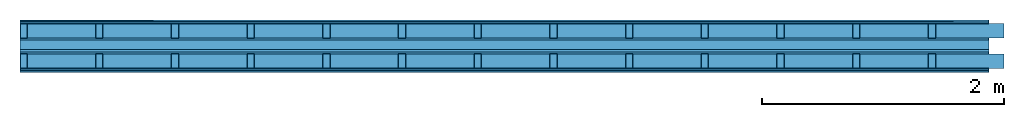
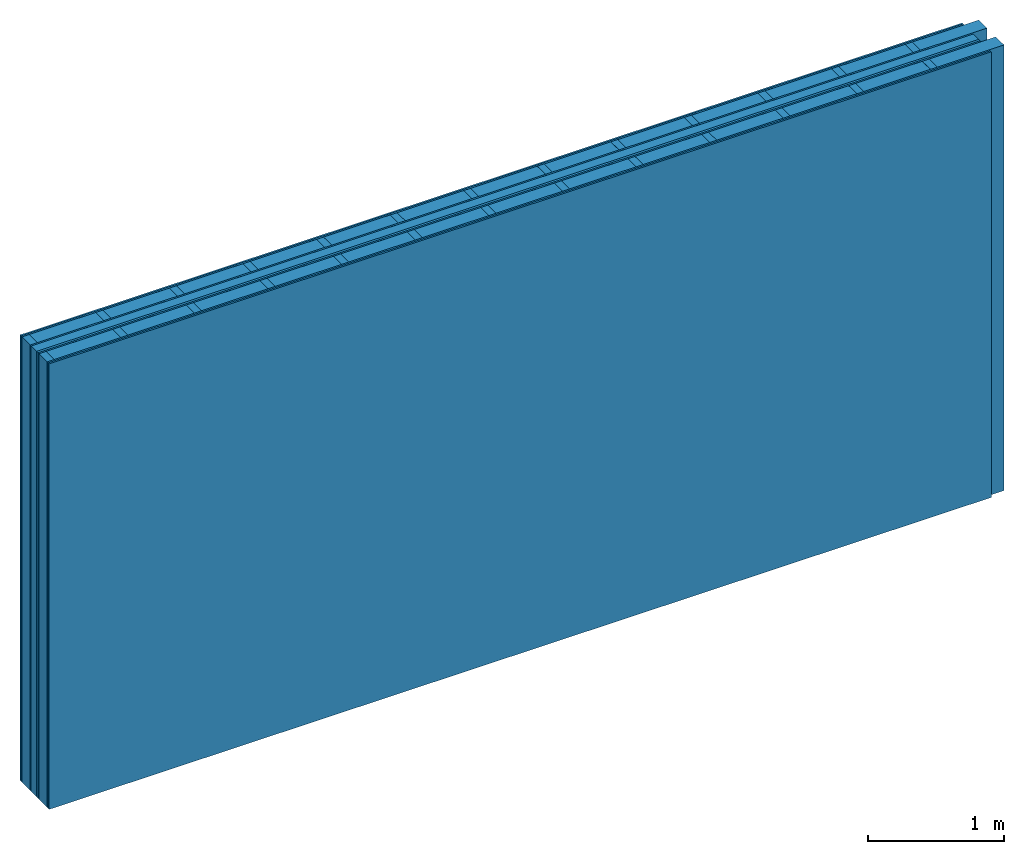
# One storey: 8 plates, 4 members, 1 element without a shape of its own.
"""IFC4 building model written with IfcOpenShell, lengths in metres."""

import ifcopenshell
import ifcopenshell.guid

model = None  # the IFC model being written
_history = None  # IfcOwnerHistory: only IFC2X3 demands one
_inside = {}  # id of a spatial element -> (the spatial element, [elements in it])
_under = {}  # id of a project, library or spatial element -> (it, [spatial elements below it])
_declared = {}  # id of a project -> (the project, [libraries it declares])
_typed = {}  # id of a type object -> (the type object, [elements of that type])
_made_of = {}  # id of a material, layer set ... -> (it, [elements and type objects made of it])


def new_model(schema):
    """Start an empty IFC model of exactly this schema.

    Asked for "IFC4X3", IfcOpenShell would pick the latest addendum, in which some entities
    have other attributes; the version numbers below select the first issue.
    IFC2X3 requires an IfcOwnerHistory on every rooted entity: one is made here for all.
    """
    global model, _history
    if schema == "IFC4X3":
        model = ifcopenshell.file(schema_version=(4, 3, 0, 0))
    else:
        model = ifcopenshell.file(schema=schema)
    _inside.clear()
    _under.clear()
    _declared.clear()
    _typed.clear()
    _made_of.clear()
    _history = None
    if model.schema == "IFC2X3":
        org = make("IfcOrganization", Name="unknown")
        user = make(
            "IfcPersonAndOrganization",
            ThePerson=make("IfcPerson", FamilyName="unknown"),
            TheOrganization=org,
        )
        app = make(
            "IfcApplication",
            ApplicationDeveloper=org,
            Version="unknown",
            ApplicationFullName="unknown",
            ApplicationIdentifier="unknown",
        )
        _history = make(
            "IfcOwnerHistory",
            OwningUser=user,
            OwningApplication=app,
            ChangeAction="ADDED",
            CreationDate=0,
        )
    return model


def make(cls, **values):
    """One entity of the class cls with the attributes given. An attribute that is None is left unset."""
    return model.create_entity(
        cls, **{name: value for name, value in values.items() if value is not None}
    )


def rooted(cls, **values):
    """An entity with a GlobalId (a new one), such as an element, a storey or a relation."""
    return make(cls, GlobalId=ifcopenshell.guid.new(), OwnerHistory=_history, **values)


def si_unit(unit_type, name, prefix=None):
    """IfcSIUnit, for example si_unit("LENGTHUNIT", "METRE", prefix="MILLI")."""
    return make("IfcSIUnit", UnitType=unit_type, Prefix=prefix, Name=name)


def derived_unit(unit_type, elements):
    """IfcDerivedUnit: a product of units, each with its exponent."""
    return make(
        "IfcDerivedUnit",
        Elements=[
            make("IfcDerivedUnitElement", Unit=unit, Exponent=power)
            for unit, power in elements
        ],
        UnitType=unit_type,
    )


def assignment(units):
    """IfcUnitAssignment: the units of a project."""
    return None if units is None else make("IfcUnitAssignment", Units=units)


def point(xyz):
    """IfcCartesianPoint."""
    return None if xyz is None else make("IfcCartesianPoint", Coordinates=xyz)


def direction(xyz):
    """IfcDirection."""
    return None if xyz is None else make("IfcDirection", DirectionRatios=xyz)


def frame(location, z_axis=None, x_axis=None):
    """IfcAxis2Placement3D, a coordinate frame: its origin and axes. An axis left out is left unset."""
    return make(
        "IfcAxis2Placement3D",
        Location=point(location),
        Axis=direction(z_axis),
        RefDirection=direction(x_axis),
    )


def frame_2d(location, x_axis=None):
    """IfcAxis2Placement2D, a coordinate frame in the plane: its origin and x axis."""
    return make(
        "IfcAxis2Placement2D", Location=point(location), RefDirection=direction(x_axis)
    )


def origin():
    """The frame at (0, 0, 0) with its axes left unset."""
    return frame((0.0, 0.0, 0.0))


def origin_with_axes():
    """The frame at (0, 0, 0) with the z axis (0, 0, 1) and the x axis (1, 0, 0) written out."""
    return frame((0.0, 0.0, 0.0), z_axis=(0.0, 0.0, 1.0), x_axis=(1.0, 0.0, 0.0))


def place(relative_to, where):
    """IfcLocalPlacement: puts the frame where relative to a parent placement (None: the world)."""
    return make(
        "IfcLocalPlacement", PlacementRelTo=relative_to, RelativePlacement=where
    )


def context(
    kind, dimensions, precision=None, world=None, true_north=None, identifier=None
):
    """IfcGeometricRepresentationContext, for example the 3D "Model" context."""
    return make(
        "IfcGeometricRepresentationContext",
        ContextIdentifier=identifier,
        ContextType=kind,
        CoordinateSpaceDimension=dimensions,
        Precision=precision,
        WorldCoordinateSystem=world,
        TrueNorth=true_north,
    )


def project(units=None, contexts=None):
    """IfcProject with its units and contexts."""
    return rooted(
        "IfcProject",
        Name="project",
        RepresentationContexts=contexts,
        UnitsInContext=assignment(units),
    )


def spatial(cls, under=None, at=None, **own):
    """A site, building, storey or space (cls), placed at a placement, below another one or the project."""
    s = rooted(cls, ObjectPlacement=at, **own)
    if under is not None:
        _under.setdefault(under.id(), (under, []))[1].append(s)
    return s


def profile(cls, at=None, kind="AREA", **sizes):
    """A parametric profile (cls). Its sizes go by their IFC names, for example OverallWidth=200.0."""
    return make(cls, ProfileType=kind, Position=at, **sizes)


def rectangle(**sizes):
    """IfcRectangleProfileDef."""
    return profile("IfcRectangleProfileDef", **sizes)


def extrude(swept, where, along, depth):
    """IfcExtrudedAreaSolid: the profile swept, set in the frame where, extruded along a direction by depth."""
    return make(
        "IfcExtrudedAreaSolid",
        SweptArea=swept,
        Position=where,
        ExtrudedDirection=direction(along),
        Depth=depth,
    )


def shape(context_of_items, identifier, shape_type, items):
    """IfcShapeRepresentation: the items that make up one representation, for example the "Body"."""
    return make(
        "IfcShapeRepresentation",
        ContextOfItems=context_of_items,
        RepresentationIdentifier=identifier,
        RepresentationType=shape_type,
        Items=items,
    )


def material(Name=None, Category=None):
    """IfcMaterial."""
    return make("IfcMaterial", Name=Name, Category=Category)


def layer(
    of_material, thickness, ventilated=None, Name=None, Category=None, Priority=None
):
    """IfcMaterialLayer: one layer of a wall or slab, of a material (None: an air gap)."""
    return make(
        "IfcMaterialLayer",
        Material=of_material,
        LayerThickness=thickness,
        IsVentilated=ventilated,
        Name=Name,
        Category=Category,
        Priority=Priority,
    )


def layer_set(layers, Name=None):
    """IfcMaterialLayerSet."""
    return make("IfcMaterialLayerSet", MaterialLayers=layers, LayerSetName=Name)


def made_of(thing, what):
    """Note that an element or type object is made of a material, layer set ...; save() writes the relation."""
    if what is not None:
        _made_of.setdefault(what.id(), (what, []))[1].append(thing)
    return thing


def type_object(cls, material=None, **own):
    """A type object (cls), such as IfcWallType, which elements share."""
    return made_of(rooted(cls, **own), material)


def element(
    cls,
    number,
    at=None,
    inside=None,
    cuts=None,
    type_object=None,
    material=None,
    context=None,
    identifier="Body",
    shape_type=None,
    held_by="IfcProductDefinitionShape",
    body=None,
    shapes=None,
    **own,
):
    """One element of the class cls, such as IfcWall. Its Tag is "e" and its number.

    at: its placement. inside: the storey or other place that contains it. cuts: it is an
    opening in that element (IfcRelVoidsElement). A single representation is given by context,
    identifier, shape_type and body (its items); several are given by shapes. held_by: the class
    of the entity that holds the representations. save() writes the other relations.
    """
    e = rooted(cls, Tag="e%d" % number, ObjectPlacement=at, **own)
    if body is not None:
        shapes = [shape(context, identifier, shape_type, body)]
    if shapes is not None:
        e.Representation = make(held_by, Representations=shapes)
    if inside is not None:
        _inside.setdefault(inside.id(), (inside, []))[1].append(e)
    if cuts is not None:
        rooted(
            "IfcRelVoidsElement", RelatingBuildingElement=cuts, RelatedOpeningElement=e
        )
    if type_object is not None:
        _typed.setdefault(type_object.id(), (type_object, []))[1].append(e)
    return made_of(e, material)


def aggregate(whole, parts):
    """IfcRelAggregates: a whole, such as a stair, and the parts it consists of."""
    return rooted("IfcRelAggregates", RelatingObject=whole, RelatedObjects=parts)


def save(model, path):
    """Write the relations noted so far, then the file.

    IfcRelAggregates (storeys below a building ...), IfcRelContainedInSpatialStructure (elements
    in a storey), IfcRelDefinesByType, IfcRelAssociatesMaterial and IfcRelDeclares: one each for
    every whole, place, type object, material and project.
    """
    for whole, parts in _under.values():
        aggregate(whole, parts)
    for where, things in _inside.values():
        rooted(
            "IfcRelContainedInSpatialStructure",
            RelatedElements=things,
            RelatingStructure=where,
        )
    for kind, things in _typed.values():
        rooted("IfcRelDefinesByType", RelatedObjects=things, RelatingType=kind)
    for what, things in _made_of.values():
        rooted("IfcRelAssociatesMaterial", RelatedObjects=things, RelatingMaterial=what)
    for by, libraries in _declared.values():
        rooted("IfcRelDeclares", RelatingContext=by, RelatedDefinitions=libraries)
    model.write(path)


model = new_model("IFC4")

# Units and contexts
plan_context = context("Plan", 3, precision=1e-05, world=origin(), true_north=direction((0.0, 1.0)))
model_context = context("Model", 3, precision=1e-05, world=origin(), true_north=direction((0.0, 1.0)))
ifc_project = project(units=[si_unit("LENGTHUNIT", "METRE"), derived_unit("SOUNDPRESSUREUNIT", [(si_unit("PRESSUREUNIT", "PASCAL", prefix="MICRO"), 0)]), si_unit("ENERGYUNIT", "JOULE", prefix="MEGA"), si_unit("MASSUNIT", "GRAM", prefix="KILO"), derived_unit("THERMALTRANSMITTANCEUNIT", [(si_unit("POWERUNIT", "WATT"), 1), (si_unit("AREAUNIT", "SQUARE_METRE"), -1), (si_unit("THERMODYNAMICTEMPERATUREUNIT", "KELVIN"), -1)]), derived_unit("AREADENSITYUNIT", [(si_unit("MASSUNIT", "GRAM", prefix="KILO"), 1), (si_unit("AREAUNIT", "SQUARE_METRE"), -1)]), derived_unit("USERDEFINED", [(si_unit("ENERGYUNIT", "JOULE", prefix="MEGA"), 1), (si_unit("AREAUNIT", "SQUARE_METRE"), -1)])], contexts=[plan_context, model_context])

# Site, building, storey
site = spatial("IfcSite", under=ifc_project)
building_placement = place(None, origin())
building = spatial("IfcBuilding", under=site, at=building_placement)
storey_placement = place(building_placement, origin())
storey = spatial("IfcBuildingStorey", under=building, at=storey_placement)

# Wall, members, plates
ifc_material_1 = material(Name="Glued joints")
ifc_layer_1 = layer(ifc_material_1, 0.0, Name="Surface")
ifc_material_2 = material(Category="03.007")
ifc_layer_2 = layer(ifc_material_2, 0.015, Name="room side 2nd layer")
ifc_layer_3 = layer(ifc_material_2, 0.015, Name="room side 1st layer")
ifc_material_3 = material(Name="of the art")
ifc_layer_4 = layer(ifc_material_3, 0.0, Name="Bond")
ifc_layer_5 = layer(None, 0.12, Name="Support")
ifc_layer_6 = layer(ifc_material_3, 0.0, Name="Bond")
ifc_layer_7 = layer(ifc_material_2, 0.015, Name="outside 1st layer")
ifc_material_4 = material()
ifc_layer_8 = layer(ifc_material_4, 0.08, Name="Intermediate insulation")
ifc_material_5 = material(Name="Air")
ifc_layer_9 = layer(ifc_material_5, 0.02, Name="Air gap")
ifc_layer_10 = layer(ifc_material_2, 0.015, Name="outside 1st layer")
ifc_layer_11 = layer(ifc_material_3, 0.0, Name="Bond")
ifc_layer_12 = layer(None, 0.12, Name="Support")
ifc_layer_13 = layer(ifc_material_3, 0.0, Name="Bond")
ifc_layer_14 = layer(ifc_material_2, 0.015, Name="room side 1st layer")
ifc_layer_15 = layer(ifc_material_2, 0.015, Name="room side 2nd layer")
ifc_layer_16 = layer(ifc_material_1, 0.0, Name="Surface")
ifc_layer_set = layer_set([ifc_layer_1, ifc_layer_2, ifc_layer_3, ifc_layer_4, ifc_layer_5, ifc_layer_6, ifc_layer_7, ifc_layer_8, ifc_layer_9, ifc_layer_10, ifc_layer_11, ifc_layer_12, ifc_layer_13, ifc_layer_14, ifc_layer_15, ifc_layer_16])
wall_type = type_object("IfcWallType", Name="B0034", PredefinedType="NOTDEFINED", material=ifc_layer_set)
wall_placement = place(None, frame((0.0, 0.0, 0.0), z_axis=(0.0, -1.0, 0.0), x_axis=(1.0, 0.0, 0.0)))
wall = element("IfcWall", 1, at=wall_placement, inside=storey, type_object=wall_type, material=ifc_layer_set, Name="Wall #1")
ifc_material_6 = material()
member_1_placement = place(wall_placement, origin())
member_1 = element("IfcMember", 2, at=member_1_placement, material=ifc_material_6, Name="Support", context=plan_context, shape_type="SweptSolid", body=[
    extrude(rectangle(XDim=0.06, YDim=0.12, at=frame_2d((0.03, 0.06), x_axis=(1.0, 0.0))), frame((0.0, 4.0, 0.03), z_axis=(0.0, -1.0, 0.0), x_axis=(1.0, 0.0, 0.0)), (0.0, 0.0, 1.0), 4.0),
    extrude(rectangle(XDim=0.06, YDim=0.12, at=frame_2d((0.03, 0.06), x_axis=(1.0, 0.0))), frame((0.625, 4.0, 0.03), z_axis=(0.0, -1.0, 0.0), x_axis=(1.0, 0.0, 0.0)), (0.0, 0.0, 1.0), 4.0),
    extrude(rectangle(XDim=0.06, YDim=0.12, at=frame_2d((0.03, 0.06), x_axis=(1.0, 0.0))), frame((1.25, 4.0, 0.03), z_axis=(0.0, -1.0, 0.0), x_axis=(1.0, 0.0, 0.0)), (0.0, 0.0, 1.0), 4.0),
    extrude(rectangle(XDim=0.06, YDim=0.12, at=frame_2d((0.03, 0.06), x_axis=(1.0, 0.0))), frame((1.875, 4.0, 0.03), z_axis=(0.0, -1.0, 0.0), x_axis=(1.0, 0.0, 0.0)), (0.0, 0.0, 1.0), 4.0),
    extrude(rectangle(XDim=0.06, YDim=0.12, at=frame_2d((0.03, 0.06), x_axis=(1.0, 0.0))), frame((2.5, 4.0, 0.03), z_axis=(0.0, -1.0, 0.0), x_axis=(1.0, 0.0, 0.0)), (0.0, 0.0, 1.0), 4.0),
    extrude(rectangle(XDim=0.06, YDim=0.12, at=frame_2d((0.03, 0.06), x_axis=(1.0, 0.0))), frame((3.125, 4.0, 0.03), z_axis=(0.0, -1.0, 0.0), x_axis=(1.0, 0.0, 0.0)), (0.0, 0.0, 1.0), 4.0),
    extrude(rectangle(XDim=0.06, YDim=0.12, at=frame_2d((0.03, 0.06), x_axis=(1.0, 0.0))), frame((3.75, 4.0, 0.03), z_axis=(0.0, -1.0, 0.0), x_axis=(1.0, 0.0, 0.0)), (0.0, 0.0, 1.0), 4.0),
    extrude(rectangle(XDim=0.06, YDim=0.12, at=frame_2d((0.03, 0.06), x_axis=(1.0, 0.0))), frame((4.375, 4.0, 0.03), z_axis=(0.0, -1.0, 0.0), x_axis=(1.0, 0.0, 0.0)), (0.0, 0.0, 1.0), 4.0),
    extrude(rectangle(XDim=0.06, YDim=0.12, at=frame_2d((0.03, 0.06), x_axis=(1.0, 0.0))), frame((5.0, 4.0, 0.03), z_axis=(0.0, -1.0, 0.0), x_axis=(1.0, 0.0, 0.0)), (0.0, 0.0, 1.0), 4.0),
    extrude(rectangle(XDim=0.06, YDim=0.12, at=frame_2d((0.03, 0.06), x_axis=(1.0, 0.0))), frame((5.625, 4.0, 0.03), z_axis=(0.0, -1.0, 0.0), x_axis=(1.0, 0.0, 0.0)), (0.0, 0.0, 1.0), 4.0),
    extrude(rectangle(XDim=0.06, YDim=0.12, at=frame_2d((0.03, 0.06), x_axis=(1.0, 0.0))), frame((6.25, 4.0, 0.03), z_axis=(0.0, -1.0, 0.0), x_axis=(1.0, 0.0, 0.0)), (0.0, 0.0, 1.0), 4.0),
    extrude(rectangle(XDim=0.06, YDim=0.12, at=frame_2d((0.03, 0.06), x_axis=(1.0, 0.0))), frame((6.875, 4.0, 0.03), z_axis=(0.0, -1.0, 0.0), x_axis=(1.0, 0.0, 0.0)), (0.0, 0.0, 1.0), 4.0),
    extrude(rectangle(XDim=0.06, YDim=0.12, at=frame_2d((0.03, 0.06), x_axis=(1.0, 0.0))), frame((7.5, 4.0, 0.03), z_axis=(0.0, -1.0, 0.0), x_axis=(1.0, 0.0, 0.0)), (0.0, 0.0, 1.0), 4.0),
])
member_2_placement = place(wall_placement, origin())
member_2 = element("IfcMember", 3, at=member_2_placement, material=ifc_material_4, Name="Cavity", context=plan_context, shape_type="SweptSolid", body=[
    extrude(rectangle(XDim=0.565, YDim=0.12, at=frame_2d((0.2825, 0.06), x_axis=(1.0, 0.0))), frame((0.06, 4.0, 0.03), z_axis=(0.0, -1.0, 0.0), x_axis=(1.0, 0.0, 0.0)), (0.0, 0.0, 1.0), 4.0),
    extrude(rectangle(XDim=0.565, YDim=0.12, at=frame_2d((0.2825, 0.06), x_axis=(1.0, 0.0))), frame((0.685, 4.0, 0.03), z_axis=(0.0, -1.0, 0.0), x_axis=(1.0, 0.0, 0.0)), (0.0, 0.0, 1.0), 4.0),
    extrude(rectangle(XDim=0.565, YDim=0.12, at=frame_2d((0.2825, 0.06), x_axis=(1.0, 0.0))), frame((1.31, 4.0, 0.03), z_axis=(0.0, -1.0, 0.0), x_axis=(1.0, 0.0, 0.0)), (0.0, 0.0, 1.0), 4.0),
    extrude(rectangle(XDim=0.565, YDim=0.12, at=frame_2d((0.2825, 0.06), x_axis=(1.0, 0.0))), frame((1.935, 4.0, 0.03), z_axis=(0.0, -1.0, 0.0), x_axis=(1.0, 0.0, 0.0)), (0.0, 0.0, 1.0), 4.0),
    extrude(rectangle(XDim=0.565, YDim=0.12, at=frame_2d((0.2825, 0.06), x_axis=(1.0, 0.0))), frame((2.56, 4.0, 0.03), z_axis=(0.0, -1.0, 0.0), x_axis=(1.0, 0.0, 0.0)), (0.0, 0.0, 1.0), 4.0),
    extrude(rectangle(XDim=0.565, YDim=0.12, at=frame_2d((0.2825, 0.06), x_axis=(1.0, 0.0))), frame((3.185, 4.0, 0.03), z_axis=(0.0, -1.0, 0.0), x_axis=(1.0, 0.0, 0.0)), (0.0, 0.0, 1.0), 4.0),
    extrude(rectangle(XDim=0.565, YDim=0.12, at=frame_2d((0.2825, 0.06), x_axis=(1.0, 0.0))), frame((3.81, 4.0, 0.03), z_axis=(0.0, -1.0, 0.0), x_axis=(1.0, 0.0, 0.0)), (0.0, 0.0, 1.0), 4.0),
    extrude(rectangle(XDim=0.565, YDim=0.12, at=frame_2d((0.2825, 0.06), x_axis=(1.0, 0.0))), frame((4.435, 4.0, 0.03), z_axis=(0.0, -1.0, 0.0), x_axis=(1.0, 0.0, 0.0)), (0.0, 0.0, 1.0), 4.0),
    extrude(rectangle(XDim=0.565, YDim=0.12, at=frame_2d((0.2825, 0.06), x_axis=(1.0, 0.0))), frame((5.06, 4.0, 0.03), z_axis=(0.0, -1.0, 0.0), x_axis=(1.0, 0.0, 0.0)), (0.0, 0.0, 1.0), 4.0),
    extrude(rectangle(XDim=0.565, YDim=0.12, at=frame_2d((0.2825, 0.06), x_axis=(1.0, 0.0))), frame((5.685, 4.0, 0.03), z_axis=(0.0, -1.0, 0.0), x_axis=(1.0, 0.0, 0.0)), (0.0, 0.0, 1.0), 4.0),
    extrude(rectangle(XDim=0.565, YDim=0.12, at=frame_2d((0.2825, 0.06), x_axis=(1.0, 0.0))), frame((6.31, 4.0, 0.03), z_axis=(0.0, -1.0, 0.0), x_axis=(1.0, 0.0, 0.0)), (0.0, 0.0, 1.0), 4.0),
    extrude(rectangle(XDim=0.565, YDim=0.12, at=frame_2d((0.2825, 0.06), x_axis=(1.0, 0.0))), frame((6.935, 4.0, 0.03), z_axis=(0.0, -1.0, 0.0), x_axis=(1.0, 0.0, 0.0)), (0.0, 0.0, 1.0), 4.0),
    extrude(rectangle(XDim=0.565, YDim=0.12, at=frame_2d((0.2825, 0.06), x_axis=(1.0, 0.0))), frame((7.56, 4.0, 0.03), z_axis=(0.0, -1.0, 0.0), x_axis=(1.0, 0.0, 0.0)), (0.0, 0.0, 1.0), 4.0),
])
member_3_placement = place(wall_placement, origin())
member_3 = element("IfcMember", 4, at=member_3_placement, material=ifc_material_6, Name="Support", context=plan_context, shape_type="SweptSolid", body=[
    extrude(rectangle(XDim=0.06, YDim=0.12, at=frame_2d((0.03, 0.06), x_axis=(1.0, 0.0))), frame((0.0, 4.0, 0.28), z_axis=(0.0, -1.0, 0.0), x_axis=(1.0, 0.0, 0.0)), (0.0, 0.0, 1.0), 4.0),
    extrude(rectangle(XDim=0.06, YDim=0.12, at=frame_2d((0.03, 0.06), x_axis=(1.0, 0.0))), frame((0.625, 4.0, 0.28), z_axis=(0.0, -1.0, 0.0), x_axis=(1.0, 0.0, 0.0)), (0.0, 0.0, 1.0), 4.0),
    extrude(rectangle(XDim=0.06, YDim=0.12, at=frame_2d((0.03, 0.06), x_axis=(1.0, 0.0))), frame((1.25, 4.0, 0.28), z_axis=(0.0, -1.0, 0.0), x_axis=(1.0, 0.0, 0.0)), (0.0, 0.0, 1.0), 4.0),
    extrude(rectangle(XDim=0.06, YDim=0.12, at=frame_2d((0.03, 0.06), x_axis=(1.0, 0.0))), frame((1.875, 4.0, 0.28), z_axis=(0.0, -1.0, 0.0), x_axis=(1.0, 0.0, 0.0)), (0.0, 0.0, 1.0), 4.0),
    extrude(rectangle(XDim=0.06, YDim=0.12, at=frame_2d((0.03, 0.06), x_axis=(1.0, 0.0))), frame((2.5, 4.0, 0.28), z_axis=(0.0, -1.0, 0.0), x_axis=(1.0, 0.0, 0.0)), (0.0, 0.0, 1.0), 4.0),
    extrude(rectangle(XDim=0.06, YDim=0.12, at=frame_2d((0.03, 0.06), x_axis=(1.0, 0.0))), frame((3.125, 4.0, 0.28), z_axis=(0.0, -1.0, 0.0), x_axis=(1.0, 0.0, 0.0)), (0.0, 0.0, 1.0), 4.0),
    extrude(rectangle(XDim=0.06, YDim=0.12, at=frame_2d((0.03, 0.06), x_axis=(1.0, 0.0))), frame((3.75, 4.0, 0.28), z_axis=(0.0, -1.0, 0.0), x_axis=(1.0, 0.0, 0.0)), (0.0, 0.0, 1.0), 4.0),
    extrude(rectangle(XDim=0.06, YDim=0.12, at=frame_2d((0.03, 0.06), x_axis=(1.0, 0.0))), frame((4.375, 4.0, 0.28), z_axis=(0.0, -1.0, 0.0), x_axis=(1.0, 0.0, 0.0)), (0.0, 0.0, 1.0), 4.0),
    extrude(rectangle(XDim=0.06, YDim=0.12, at=frame_2d((0.03, 0.06), x_axis=(1.0, 0.0))), frame((5.0, 4.0, 0.28), z_axis=(0.0, -1.0, 0.0), x_axis=(1.0, 0.0, 0.0)), (0.0, 0.0, 1.0), 4.0),
    extrude(rectangle(XDim=0.06, YDim=0.12, at=frame_2d((0.03, 0.06), x_axis=(1.0, 0.0))), frame((5.625, 4.0, 0.28), z_axis=(0.0, -1.0, 0.0), x_axis=(1.0, 0.0, 0.0)), (0.0, 0.0, 1.0), 4.0),
    extrude(rectangle(XDim=0.06, YDim=0.12, at=frame_2d((0.03, 0.06), x_axis=(1.0, 0.0))), frame((6.25, 4.0, 0.28), z_axis=(0.0, -1.0, 0.0), x_axis=(1.0, 0.0, 0.0)), (0.0, 0.0, 1.0), 4.0),
    extrude(rectangle(XDim=0.06, YDim=0.12, at=frame_2d((0.03, 0.06), x_axis=(1.0, 0.0))), frame((6.875, 4.0, 0.28), z_axis=(0.0, -1.0, 0.0), x_axis=(1.0, 0.0, 0.0)), (0.0, 0.0, 1.0), 4.0),
    extrude(rectangle(XDim=0.06, YDim=0.12, at=frame_2d((0.03, 0.06), x_axis=(1.0, 0.0))), frame((7.5, 4.0, 0.28), z_axis=(0.0, -1.0, 0.0), x_axis=(1.0, 0.0, 0.0)), (0.0, 0.0, 1.0), 4.0),
])
member_4_placement = place(wall_placement, origin())
member_4 = element("IfcMember", 5, at=member_4_placement, material=ifc_material_4, Name="Cavity", context=plan_context, shape_type="SweptSolid", body=[
    extrude(rectangle(XDim=0.565, YDim=0.12, at=frame_2d((0.2825, 0.06), x_axis=(1.0, 0.0))), frame((0.06, 4.0, 0.28), z_axis=(0.0, -1.0, 0.0), x_axis=(1.0, 0.0, 0.0)), (0.0, 0.0, 1.0), 4.0),
    extrude(rectangle(XDim=0.565, YDim=0.12, at=frame_2d((0.2825, 0.06), x_axis=(1.0, 0.0))), frame((0.685, 4.0, 0.28), z_axis=(0.0, -1.0, 0.0), x_axis=(1.0, 0.0, 0.0)), (0.0, 0.0, 1.0), 4.0),
    extrude(rectangle(XDim=0.565, YDim=0.12, at=frame_2d((0.2825, 0.06), x_axis=(1.0, 0.0))), frame((1.31, 4.0, 0.28), z_axis=(0.0, -1.0, 0.0), x_axis=(1.0, 0.0, 0.0)), (0.0, 0.0, 1.0), 4.0),
    extrude(rectangle(XDim=0.565, YDim=0.12, at=frame_2d((0.2825, 0.06), x_axis=(1.0, 0.0))), frame((1.935, 4.0, 0.28), z_axis=(0.0, -1.0, 0.0), x_axis=(1.0, 0.0, 0.0)), (0.0, 0.0, 1.0), 4.0),
    extrude(rectangle(XDim=0.565, YDim=0.12, at=frame_2d((0.2825, 0.06), x_axis=(1.0, 0.0))), frame((2.56, 4.0, 0.28), z_axis=(0.0, -1.0, 0.0), x_axis=(1.0, 0.0, 0.0)), (0.0, 0.0, 1.0), 4.0),
    extrude(rectangle(XDim=0.565, YDim=0.12, at=frame_2d((0.2825, 0.06), x_axis=(1.0, 0.0))), frame((3.185, 4.0, 0.28), z_axis=(0.0, -1.0, 0.0), x_axis=(1.0, 0.0, 0.0)), (0.0, 0.0, 1.0), 4.0),
    extrude(rectangle(XDim=0.565, YDim=0.12, at=frame_2d((0.2825, 0.06), x_axis=(1.0, 0.0))), frame((3.81, 4.0, 0.28), z_axis=(0.0, -1.0, 0.0), x_axis=(1.0, 0.0, 0.0)), (0.0, 0.0, 1.0), 4.0),
    extrude(rectangle(XDim=0.565, YDim=0.12, at=frame_2d((0.2825, 0.06), x_axis=(1.0, 0.0))), frame((4.435, 4.0, 0.28), z_axis=(0.0, -1.0, 0.0), x_axis=(1.0, 0.0, 0.0)), (0.0, 0.0, 1.0), 4.0),
    extrude(rectangle(XDim=0.565, YDim=0.12, at=frame_2d((0.2825, 0.06), x_axis=(1.0, 0.0))), frame((5.06, 4.0, 0.28), z_axis=(0.0, -1.0, 0.0), x_axis=(1.0, 0.0, 0.0)), (0.0, 0.0, 1.0), 4.0),
    extrude(rectangle(XDim=0.565, YDim=0.12, at=frame_2d((0.2825, 0.06), x_axis=(1.0, 0.0))), frame((5.685, 4.0, 0.28), z_axis=(0.0, -1.0, 0.0), x_axis=(1.0, 0.0, 0.0)), (0.0, 0.0, 1.0), 4.0),
    extrude(rectangle(XDim=0.565, YDim=0.12, at=frame_2d((0.2825, 0.06), x_axis=(1.0, 0.0))), frame((6.31, 4.0, 0.28), z_axis=(0.0, -1.0, 0.0), x_axis=(1.0, 0.0, 0.0)), (0.0, 0.0, 1.0), 4.0),
    extrude(rectangle(XDim=0.565, YDim=0.12, at=frame_2d((0.2825, 0.06), x_axis=(1.0, 0.0))), frame((6.935, 4.0, 0.28), z_axis=(0.0, -1.0, 0.0), x_axis=(1.0, 0.0, 0.0)), (0.0, 0.0, 1.0), 4.0),
    extrude(rectangle(XDim=0.565, YDim=0.12, at=frame_2d((0.2825, 0.06), x_axis=(1.0, 0.0))), frame((7.56, 4.0, 0.28), z_axis=(0.0, -1.0, 0.0), x_axis=(1.0, 0.0, 0.0)), (0.0, 0.0, 1.0), 4.0),
])
plate_1_placement = place(wall_placement, origin())
plate_1 = element("IfcPlate", 6, at=plate_1_placement, material=ifc_material_2, Name="room side 2nd layer", context=plan_context, shape_type="SweptSolid", body=[
    extrude(rectangle(XDim=8.0, YDim=4.0, at=frame_2d((4.0, 2.0), x_axis=(1.0, 0.0))), origin_with_axes(), (0.0, 0.0, 1.0), 0.015),
])
plate_2_placement = place(wall_placement, origin())
plate_2 = element("IfcPlate", 7, at=plate_2_placement, material=ifc_material_2, Name="room side 1st layer", context=plan_context, shape_type="SweptSolid", body=[
    extrude(rectangle(XDim=8.0, YDim=4.0, at=frame_2d((4.0, 2.0), x_axis=(1.0, 0.0))), frame((0.0, 0.0, 0.015), z_axis=(0.0, 0.0, 1.0), x_axis=(1.0, 0.0, 0.0)), (0.0, 0.0, 1.0), 0.015),
])
plate_3_placement = place(wall_placement, origin())
plate_3 = element("IfcPlate", 8, at=plate_3_placement, material=ifc_material_2, Name="outside 1st layer", context=plan_context, shape_type="SweptSolid", body=[
    extrude(rectangle(XDim=8.0, YDim=4.0, at=frame_2d((4.0, 2.0), x_axis=(1.0, 0.0))), frame((0.0, 0.0, 0.15), z_axis=(0.0, 0.0, 1.0), x_axis=(1.0, 0.0, 0.0)), (0.0, 0.0, 1.0), 0.015),
])
plate_4_placement = place(wall_placement, origin())
plate_4 = element("IfcPlate", 9, at=plate_4_placement, material=ifc_material_4, Name="Intermediate insulation", context=plan_context, shape_type="SweptSolid", body=[
    extrude(rectangle(XDim=8.0, YDim=4.0, at=frame_2d((4.0, 2.0), x_axis=(1.0, 0.0))), frame((0.0, 0.0, 0.165), z_axis=(0.0, 0.0, 1.0), x_axis=(1.0, 0.0, 0.0)), (0.0, 0.0, 1.0), 0.08),
])
plate_5_placement = place(wall_placement, origin())
plate_5 = element("IfcPlate", 10, at=plate_5_placement, material=ifc_material_5, Name="Air gap", context=plan_context, shape_type="SweptSolid", body=[
    extrude(rectangle(XDim=8.0, YDim=4.0, at=frame_2d((4.0, 2.0), x_axis=(1.0, 0.0))), frame((0.0, 0.0, 0.245), z_axis=(0.0, 0.0, 1.0), x_axis=(1.0, 0.0, 0.0)), (0.0, 0.0, 1.0), 0.02),
])
plate_6_placement = place(wall_placement, origin())
plate_6 = element("IfcPlate", 11, at=plate_6_placement, material=ifc_material_2, Name="outside 1st layer", context=plan_context, shape_type="SweptSolid", body=[
    extrude(rectangle(XDim=8.0, YDim=4.0, at=frame_2d((4.0, 2.0), x_axis=(1.0, 0.0))), frame((0.0, 0.0, 0.265), z_axis=(0.0, 0.0, 1.0), x_axis=(1.0, 0.0, 0.0)), (0.0, 0.0, 1.0), 0.015),
])
plate_7_placement = place(wall_placement, origin())
plate_7 = element("IfcPlate", 12, at=plate_7_placement, material=ifc_material_2, Name="room side 1st layer", context=plan_context, shape_type="SweptSolid", body=[
    extrude(rectangle(XDim=8.0, YDim=4.0, at=frame_2d((4.0, 2.0), x_axis=(1.0, 0.0))), frame((0.0, 0.0, 0.4), z_axis=(0.0, 0.0, 1.0), x_axis=(1.0, 0.0, 0.0)), (0.0, 0.0, 1.0), 0.015),
])
plate_8_placement = place(wall_placement, origin())
plate_8 = element("IfcPlate", 13, at=plate_8_placement, material=ifc_material_2, Name="room side 2nd layer", context=plan_context, shape_type="SweptSolid", body=[
    extrude(rectangle(XDim=8.0, YDim=4.0, at=frame_2d((4.0, 2.0), x_axis=(1.0, 0.0))), frame((0.0, 0.0, 0.415), z_axis=(0.0, 0.0, 1.0), x_axis=(1.0, 0.0, 0.0)), (0.0, 0.0, 1.0), 0.015),
])
aggregate(wall, [plate_1, plate_2, member_1, member_2, plate_3, plate_4, plate_5, plate_6, member_3, member_4, plate_7, plate_8])

save(model, "model.ifc")
